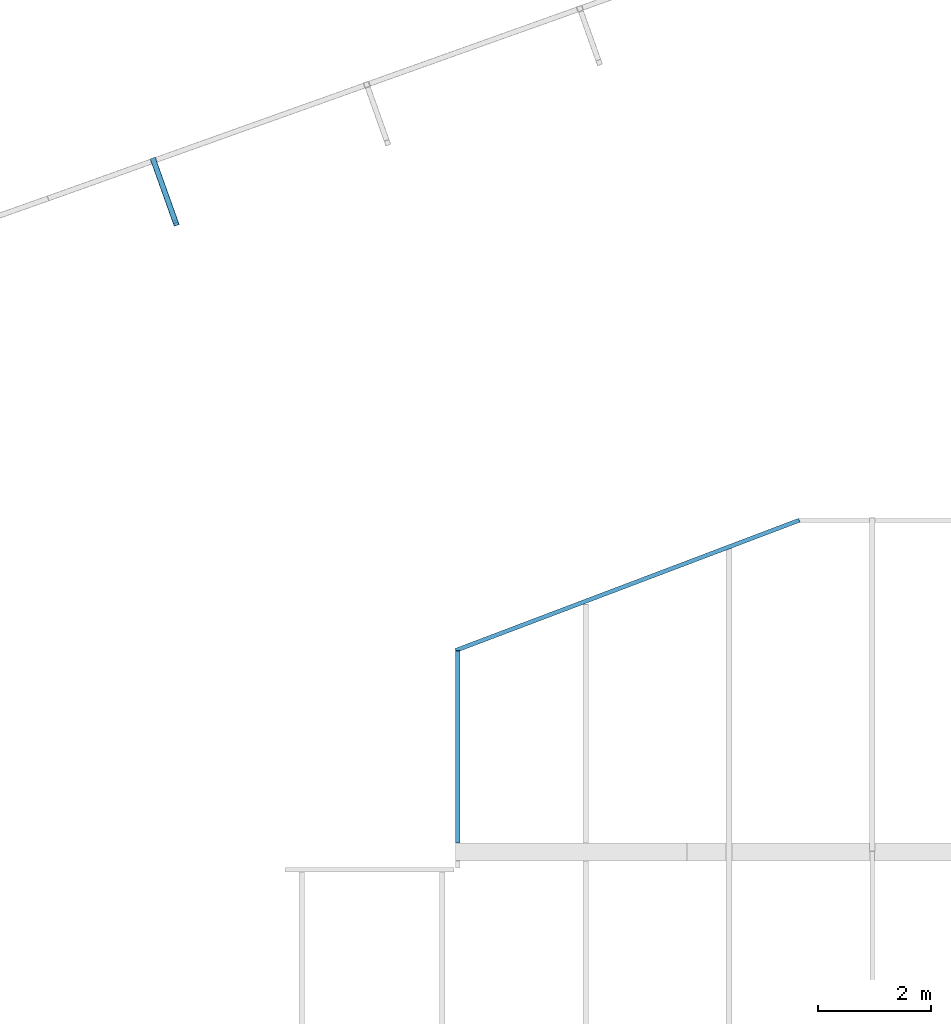
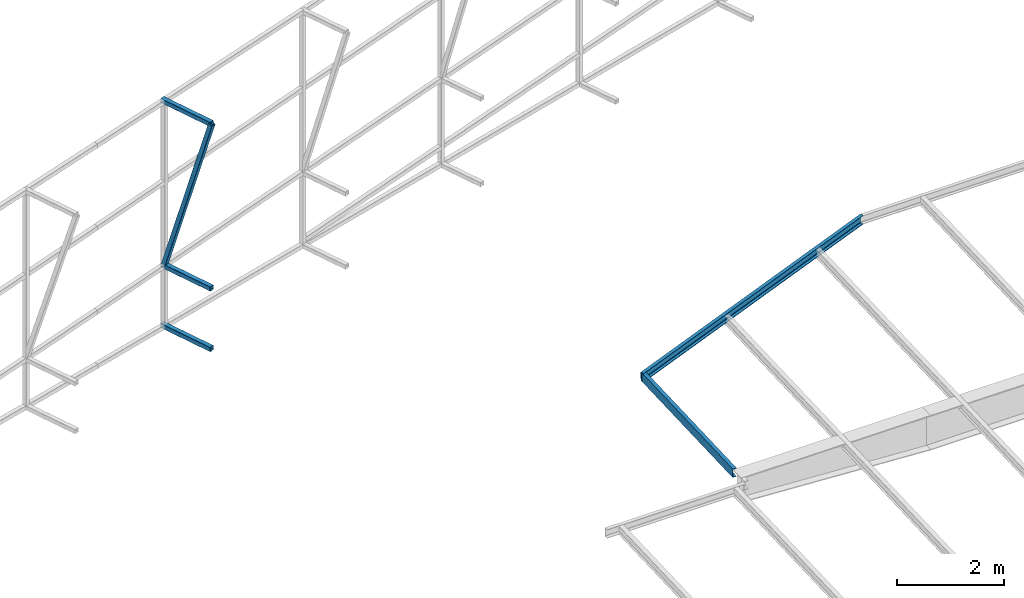
# One storey, part 127 of 215: 5 beams, 1 member, 6 elements without a shape of their own.
"""IFC2X3 building model written with IfcOpenShell, lengths in millimetres."""

import ifcopenshell
import ifcopenshell.guid

model = None  # the IFC model being written
_history = None  # IfcOwnerHistory: only IFC2X3 demands one
_inside = {}  # id of a spatial element -> (the spatial element, [elements in it])
_under = {}  # id of a project, library or spatial element -> (it, [spatial elements below it])
_declared = {}  # id of a project -> (the project, [libraries it declares])
_typed = {}  # id of a type object -> (the type object, [elements of that type])
_made_of = {}  # id of a material, layer set ... -> (it, [elements and type objects made of it])


def new_model(schema):
    """Start an empty IFC model of exactly this schema.

    Asked for "IFC4X3", IfcOpenShell would pick the latest addendum, in which some entities
    have other attributes; the version numbers below select the first issue.
    IFC2X3 requires an IfcOwnerHistory on every rooted entity: one is made here for all.
    """
    global model, _history
    if schema == "IFC4X3":
        model = ifcopenshell.file(schema_version=(4, 3, 0, 0))
    else:
        model = ifcopenshell.file(schema=schema)
    _inside.clear()
    _under.clear()
    _declared.clear()
    _typed.clear()
    _made_of.clear()
    _history = None
    if model.schema == "IFC2X3":
        org = make("IfcOrganization", Name="unknown")
        user = make(
            "IfcPersonAndOrganization",
            ThePerson=make("IfcPerson", FamilyName="unknown"),
            TheOrganization=org,
        )
        app = make(
            "IfcApplication",
            ApplicationDeveloper=org,
            Version="unknown",
            ApplicationFullName="unknown",
            ApplicationIdentifier="unknown",
        )
        _history = make(
            "IfcOwnerHistory",
            OwningUser=user,
            OwningApplication=app,
            ChangeAction="ADDED",
            CreationDate=0,
        )
    return model


def make(cls, **values):
    """One entity of the class cls with the attributes given. An attribute that is None is left unset."""
    return model.create_entity(
        cls, **{name: value for name, value in values.items() if value is not None}
    )


def rooted(cls, **values):
    """An entity with a GlobalId (a new one), such as an element, a storey or a relation."""
    return make(cls, GlobalId=ifcopenshell.guid.new(), OwnerHistory=_history, **values)


def si_unit(unit_type, name, prefix=None):
    """IfcSIUnit, for example si_unit("LENGTHUNIT", "METRE", prefix="MILLI")."""
    return make("IfcSIUnit", UnitType=unit_type, Prefix=prefix, Name=name)


def assignment(units):
    """IfcUnitAssignment: the units of a project."""
    return None if units is None else make("IfcUnitAssignment", Units=units)


def point(xyz):
    """IfcCartesianPoint."""
    return None if xyz is None else make("IfcCartesianPoint", Coordinates=xyz)


def direction(xyz):
    """IfcDirection."""
    return None if xyz is None else make("IfcDirection", DirectionRatios=xyz)


def frame(location, z_axis=None, x_axis=None):
    """IfcAxis2Placement3D, a coordinate frame: its origin and axes. An axis left out is left unset."""
    return make(
        "IfcAxis2Placement3D",
        Location=point(location),
        Axis=direction(z_axis),
        RefDirection=direction(x_axis),
    )


def frame_2d(location, x_axis=None):
    """IfcAxis2Placement2D, a coordinate frame in the plane: its origin and x axis."""
    return make(
        "IfcAxis2Placement2D", Location=point(location), RefDirection=direction(x_axis)
    )


def origin_with_axes():
    """The frame at (0, 0, 0) with the z axis (0, 0, 1) and the x axis (1, 0, 0) written out."""
    return frame((0.0, 0.0, 0.0), z_axis=(0.0, 0.0, 1.0), x_axis=(1.0, 0.0, 0.0))


def origin_2d_with_axis():
    """The frame at (0, 0) in the plane with the x axis (1, 0) written out."""
    return frame_2d((0.0, 0.0), x_axis=(1.0, 0.0))


def place(relative_to, where):
    """IfcLocalPlacement: puts the frame where relative to a parent placement (None: the world)."""
    return make(
        "IfcLocalPlacement", PlacementRelTo=relative_to, RelativePlacement=where
    )


def context(
    kind, dimensions, precision=None, world=None, true_north=None, identifier=None
):
    """IfcGeometricRepresentationContext, for example the 3D "Model" context."""
    return make(
        "IfcGeometricRepresentationContext",
        ContextIdentifier=identifier,
        ContextType=kind,
        CoordinateSpaceDimension=dimensions,
        Precision=precision,
        WorldCoordinateSystem=world,
        TrueNorth=true_north,
    )


def subcontext(parent, identifier, kind, view, scale=None):
    """IfcGeometricRepresentationSubContext, for example "Body" below "Model"."""
    return make(
        "IfcGeometricRepresentationSubContext",
        ContextIdentifier=identifier,
        ContextType=kind,
        ParentContext=parent,
        TargetScale=scale,
        TargetView=view,
    )


def project(units=None, contexts=None):
    """IfcProject with its units and contexts."""
    return rooted(
        "IfcProject",
        Name="project",
        RepresentationContexts=contexts,
        UnitsInContext=assignment(units),
    )


def spatial(cls, under=None, at=None, **own):
    """A site, building, storey or space (cls), placed at a placement, below another one or the project."""
    s = rooted(cls, ObjectPlacement=at, **own)
    if under is not None:
        _under.setdefault(under.id(), (under, []))[1].append(s)
    return s


def profile(cls, at=None, kind="AREA", **sizes):
    """A parametric profile (cls). Its sizes go by their IFC names, for example OverallWidth=200.0."""
    return make(cls, ProfileType=kind, Position=at, **sizes)


def hollow_rectangle(**sizes):
    """IfcRectangleHollowProfileDef."""
    return profile("IfcRectangleHollowProfileDef", **sizes)


def u_section(**sizes):
    """IfcUShapeProfileDef."""
    return profile("IfcUShapeProfileDef", **sizes)


def extrude(swept, where, along, depth):
    """IfcExtrudedAreaSolid: the profile swept, set in the frame where, extruded along a direction by depth."""
    return make(
        "IfcExtrudedAreaSolid",
        SweptArea=swept,
        Position=where,
        ExtrudedDirection=direction(along),
        Depth=depth,
    )


def shape(context_of_items, identifier, shape_type, items):
    """IfcShapeRepresentation: the items that make up one representation, for example the "Body"."""
    return make(
        "IfcShapeRepresentation",
        ContextOfItems=context_of_items,
        RepresentationIdentifier=identifier,
        RepresentationType=shape_type,
        Items=items,
    )


def material(Name=None, Category=None):
    """IfcMaterial."""
    return make("IfcMaterial", Name=Name, Category=Category)


def made_of(thing, what):
    """Note that an element or type object is made of a material, layer set ...; save() writes the relation."""
    if what is not None:
        _made_of.setdefault(what.id(), (what, []))[1].append(thing)
    return thing


def type_object(cls, material=None, **own):
    """A type object (cls), such as IfcWallType, which elements share."""
    return made_of(rooted(cls, **own), material)


def element(
    cls,
    number,
    at=None,
    inside=None,
    cuts=None,
    type_object=None,
    material=None,
    context=None,
    identifier="Body",
    shape_type=None,
    held_by="IfcProductDefinitionShape",
    body=None,
    shapes=None,
    **own,
):
    """One element of the class cls, such as IfcWall. Its Tag is "e" and its number.

    at: its placement. inside: the storey or other place that contains it. cuts: it is an
    opening in that element (IfcRelVoidsElement). A single representation is given by context,
    identifier, shape_type and body (its items); several are given by shapes. held_by: the class
    of the entity that holds the representations. save() writes the other relations.
    """
    e = rooted(cls, Tag="e%d" % number, ObjectPlacement=at, **own)
    if body is not None:
        shapes = [shape(context, identifier, shape_type, body)]
    if shapes is not None:
        e.Representation = make(held_by, Representations=shapes)
    if inside is not None:
        _inside.setdefault(inside.id(), (inside, []))[1].append(e)
    if cuts is not None:
        rooted(
            "IfcRelVoidsElement", RelatingBuildingElement=cuts, RelatedOpeningElement=e
        )
    if type_object is not None:
        _typed.setdefault(type_object.id(), (type_object, []))[1].append(e)
    return made_of(e, material)


def aggregate(whole, parts):
    """IfcRelAggregates: a whole, such as a stair, and the parts it consists of."""
    return rooted("IfcRelAggregates", RelatingObject=whole, RelatedObjects=parts)


def save(model, path):
    """Write the relations noted so far, then the file.

    IfcRelAggregates (storeys below a building ...), IfcRelContainedInSpatialStructure (elements
    in a storey), IfcRelDefinesByType, IfcRelAssociatesMaterial and IfcRelDeclares: one each for
    every whole, place, type object, material and project.
    """
    for whole, parts in _under.values():
        aggregate(whole, parts)
    for where, things in _inside.values():
        rooted(
            "IfcRelContainedInSpatialStructure",
            RelatedElements=things,
            RelatingStructure=where,
        )
    for kind, things in _typed.values():
        rooted("IfcRelDefinesByType", RelatedObjects=things, RelatingType=kind)
    for what, things in _made_of.values():
        rooted("IfcRelAssociatesMaterial", RelatedObjects=things, RelatingMaterial=what)
    for by, libraries in _declared.values():
        rooted("IfcRelDeclares", RelatingContext=by, RelatedDefinitions=libraries)
    model.write(path)


model = new_model("IFC2X3")

# Units and contexts
model_context = context("Model", 3, precision=1e-05, world=origin_with_axes())
body_context = subcontext(model_context, "Body", "Model", "MODEL_VIEW")
ifc_project = project(units=[si_unit("LENGTHUNIT", "METRE", prefix="MILLI"), si_unit("AREAUNIT", "SQUARE_METRE"), si_unit("VOLUMEUNIT", "CUBIC_METRE"), si_unit("MASSUNIT", "GRAM", prefix="KILO"), si_unit("TIMEUNIT", "SECOND"), si_unit("PLANEANGLEUNIT", "RADIAN"), si_unit("SOLIDANGLEUNIT", "STERADIAN"), si_unit("THERMODYNAMICTEMPERATUREUNIT", "DEGREE_CELSIUS"), si_unit("LUMINOUSINTENSITYUNIT", "LUMEN")], contexts=[model_context])

# Site, building, storey
site_placement = place(None, origin_with_axes())
site = spatial("IfcSite", under=ifc_project, at=site_placement, CompositionType="ELEMENT")
building_placement = place(site_placement, origin_with_axes())
building = spatial("IfcBuilding", under=site, at=building_placement, Name="Undefined", CompositionType="ELEMENT")
storey_placement = place(building_placement, origin_with_axes())
storey = spatial("IfcBuildingStorey", under=building, at=storey_placement, Name="Undefined", CompositionType="ELEMENT", Elevation=0.0)

# Assembly, beam
assembly_1_placement = place(storey_placement, origin_with_axes())
assembly_1 = element("IfcElementAssembly", 1, at=assembly_1_placement, inside=storey, Name="Steel Assembly", AssemblyPlace="NOTDEFINED", PredefinedType="RIGID_FRAME")
ifc_material = material(Name="STEEL/S275JR")
beam_type_1 = type_object("IfcBeamType", PredefinedType="NOTDEFINED")
beam_1_placement = place(assembly_1_placement, frame((101943.33856111, 73724.9012174709, 1873.72640562236), z_axis=(0.941802170974673, 0.33616762299096, 0.0), x_axis=(-0.336167626855526, 0.941802169595252, 0.0)))
beam_1 = element("IfcBeam", 2, at=beam_1_placement, type_object=beam_type_1, material=ifc_material, Name="LISSE", context=body_context, shape_type="SweptSolid", body=[
    extrude(hollow_rectangle(XDim=100.0, YDim=100.0, WallThickness=4.0, InnerFilletRadius=4.0, OuterFilletRadius=8.0, at=origin_2d_with_axis()), frame((1220.71940266879, 0.0, -6.77635393724778e-14), z_axis=(-1.0, 0.0, 0.0), x_axis=(-6.93889390390723e-18, -1.0, -3.46944695195361e-18)), (0.0, 0.0, 1.0), 1220.7),
])
aggregate(assembly_1, [beam_1])

assembly_2_placement = place(storey_placement, origin_with_axes())
assembly_2 = element("IfcElementAssembly", 3, at=assembly_2_placement, inside=storey, Name="Steel Assembly", AssemblyPlace="NOTDEFINED", PredefinedType="RIGID_FRAME")
beam_2_placement = place(assembly_2_placement, frame((101943.338554507, 73724.9012165357, 3259.9979099935), z_axis=(0.941802170974673, 0.33616762299096, 0.0), x_axis=(-0.336167626855526, 0.941802169595252, 0.0)))
beam_2 = element("IfcBeam", 4, at=beam_2_placement, type_object=beam_type_1, material=ifc_material, Name="LISSE", context=body_context, shape_type="SweptSolid", body=[
    extrude(hollow_rectangle(XDim=100.0, YDim=100.0, WallThickness=4.0, InnerFilletRadius=4.0, OuterFilletRadius=8.0, at=origin_2d_with_axis()), frame((1220.71940266879, 0.0, -6.77635393724778e-14), z_axis=(-1.0, 0.0, 0.0), x_axis=(-6.93889390390723e-18, -1.0, -3.46944695195361e-18)), (0.0, 0.0, 1.0), 1220.7),
])
aggregate(assembly_2, [beam_2])

assembly_3_placement = place(storey_placement, origin_with_axes())
assembly_3 = element("IfcElementAssembly", 5, at=assembly_3_placement, inside=storey, Name="Steel Assembly", AssemblyPlace="NOTDEFINED", PredefinedType="RIGID_FRAME")
beam_3_placement = place(assembly_3_placement, frame((101943.338562818, 73724.9012177056, 7030.24925153639), z_axis=(0.941802170974673, 0.33616762299096, 0.0), x_axis=(-0.336167626855526, 0.941802169595252, 0.0)))
beam_3 = element("IfcBeam", 6, at=beam_3_placement, type_object=beam_type_1, material=ifc_material, Name="LISSE", context=body_context, shape_type="SweptSolid", body=[
    extrude(hollow_rectangle(XDim=100.0, YDim=100.0, WallThickness=4.0, InnerFilletRadius=4.0, OuterFilletRadius=8.0, at=origin_2d_with_axis()), frame((1220.71940266879, 0.0, -6.77635393724778e-14), z_axis=(-1.0, 0.0, 0.0), x_axis=(-6.93889390390723e-18, -1.0, -3.46944695195361e-18)), (0.0, 0.0, 1.0), 1220.7),
])
aggregate(assembly_3, [beam_3])

# Assembly, member
assembly_4_placement = place(storey_placement, origin_with_axes())
assembly_4 = element("IfcElementAssembly", 7, at=assembly_4_placement, inside=storey, Name="Steel Assembly", AssemblyPlace="NOTDEFINED", PredefinedType="RIGID_FRAME")
member_type = type_object("IfcMemberType", PredefinedType="NOTDEFINED")
member_placement = place(assembly_4_placement, frame((101943.338562818, 73724.9012177056, 7030.24925153639), z_axis=(0.941802170974673, 0.33616762299096, 0.0), x_axis=(-0.0996896389558097, 0.279288990876192, -0.955018133576645)))
member = element("IfcMember", 8, at=member_placement, type_object=member_type, material=ifc_material, Name="LISSE", context=body_context, shape_type="SweptSolid", body=[
    extrude(hollow_rectangle(XDim=100.0, YDim=100.0, WallThickness=4.0, InnerFilletRadius=4.0, OuterFilletRadius=8.0, at=origin_2d_with_axis()), frame((3947.83220242751, 7.27595761418343e-12, 1.45143777213136e-11), z_axis=(-1.0, 0.0, 0.0), x_axis=(-6.93889390390723e-18, -1.0, -3.46944695195361e-18)), (0.0, 0.0, 1.0), 3947.8),
])
aggregate(assembly_4, [member])

# Assembly, beam
assembly_5_placement = place(storey_placement, origin_with_axes())
assembly_5 = element("IfcElementAssembly", 9, at=assembly_5_placement, inside=storey, Name="Steel Assembly", AssemblyPlace="NOTDEFINED", PredefinedType="RIGID_FRAME")
beam_type_2 = type_object("IfcBeamType", Name="UPN200", PredefinedType="NOTDEFINED")
beam_4_placement = place(assembly_5_placement, frame((112990.311819509, 68458.0551052303, 4170.64519454668), z_axis=(0.0132576730022094, 0.00500876100083927, -0.999899568166625), x_axis=(-0.935009289486287, -0.354339914805317, -0.0141722739922134)))
beam_4 = element("IfcBeam", 10, at=beam_4_placement, type_object=beam_type_2, material=ifc_material, ObjectType="UPN200", context=body_context, shape_type="SweptSolid", body=[
    extrude(u_section(Depth=200.0, FlangeWidth=75.0, WebThickness=8.5, FlangeThickness=11.5, FilletRadius=11.5, EdgeRadius=6.0, FlangeSlope=0.0798299857122373, at=origin_2d_with_axis()), frame((6515.02025757921, -1.77157311475509e-11, 4.54747350886464e-13), z_axis=(-1.0, 0.0, 0.0), x_axis=(-6.93889390390723e-18, -1.0, -3.46944695195361e-18)), (0.0, 0.0, 1.0), 6515.0),
])
aggregate(assembly_5, [beam_4])

assembly_6_placement = place(storey_placement, origin_with_axes())
assembly_6 = element("IfcElementAssembly", 11, at=assembly_6_placement, inside=storey, Name="Steel Assembly", AssemblyPlace="NOTDEFINED", PredefinedType="RIGID_FRAME")
beam_type_3 = type_object("IfcBeamType", Name="UPE200", PredefinedType="NOTDEFINED")
beam_5_placement = place(assembly_6_placement, frame((106934.082048172, 62745.67621763, 3940.58473305577), z_axis=(0.0, -0.0399624260079826, 0.999201183199638), x_axis=(0.0, 0.999201183199638, 0.0399624260079844)))
beam_5 = element("IfcBeam", 12, at=beam_5_placement, type_object=beam_type_3, material=ifc_material, ObjectType="UPE200", context=body_context, shape_type="SweptSolid", body=[
    extrude(u_section(Depth=200.0, FlangeWidth=80.0, WebThickness=6.0, FlangeThickness=11.0, FilletRadius=13.0, at=origin_2d_with_axis()), frame((3406.18940612058, 0.0, -2.36351869056835e-14), z_axis=(-1.0, 0.0, 0.0), x_axis=(-6.93889390390723e-18, -1.0, -3.46944695195361e-18)), (0.0, 0.0, 1.0), 3406.2),
])
aggregate(assembly_6, [beam_5])

save(model, "model.ifc")
